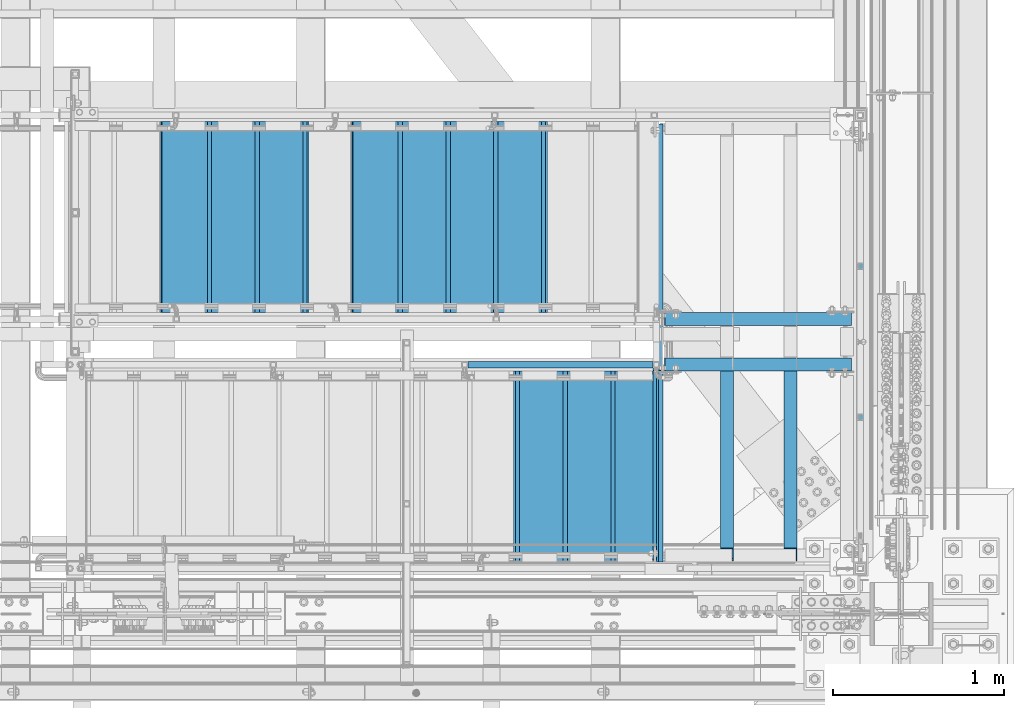
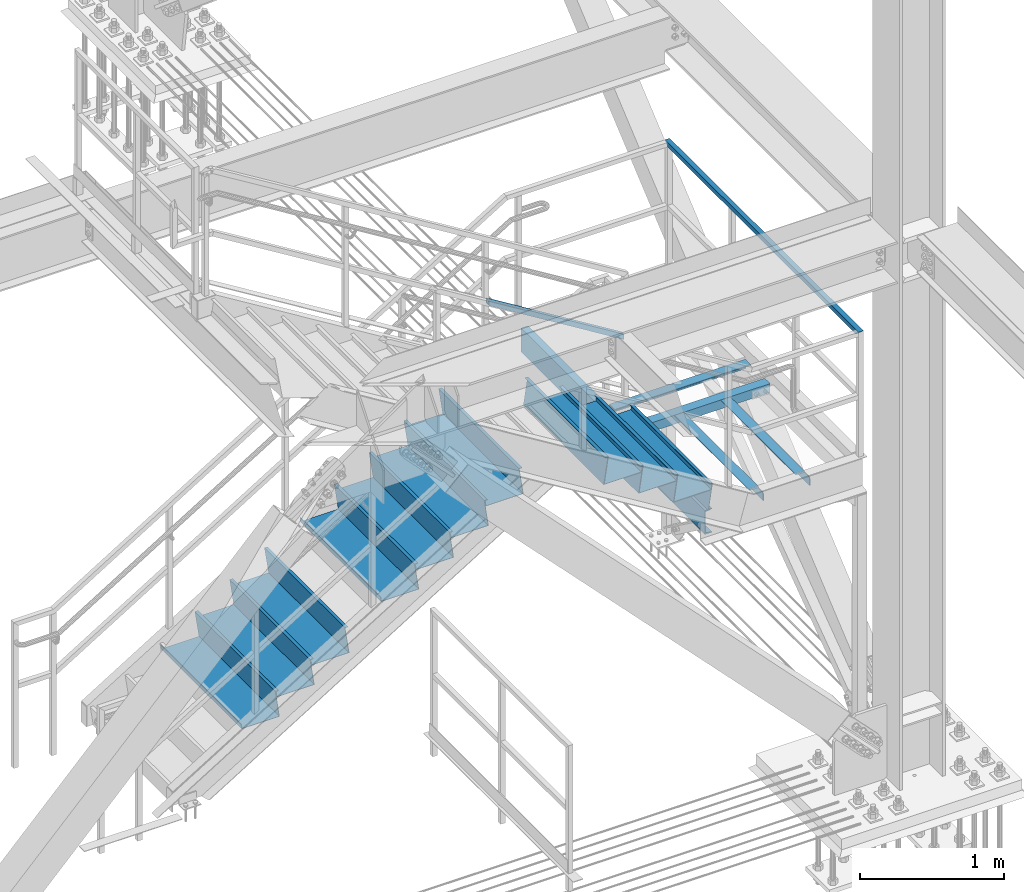
# One storey, part 1948 of 3843: 17 beams, 1 member, 9 elements without a shape of their own.
"""IFC2X3 building model written with IfcOpenShell, lengths in millimetres."""

from ifc_helpers import new_model, si_unit, frame, origin_with_axes, place, context, subcontext, project, spatial, faceted_brep, material, type_object, element, aggregate, save


model = new_model("IFC2X3")

# Units and contexts
model_context = context("Model", 3, precision=1e-05, world=origin_with_axes())
body_context = subcontext(model_context, "Body", "Model", "MODEL_VIEW")
ifc_project = project(units=[si_unit("LENGTHUNIT", "METRE", prefix="MILLI"), si_unit("AREAUNIT", "SQUARE_METRE"), si_unit("VOLUMEUNIT", "CUBIC_METRE"), si_unit("MASSUNIT", "GRAM", prefix="KILO"), si_unit("TIMEUNIT", "SECOND"), si_unit("PLANEANGLEUNIT", "RADIAN"), si_unit("SOLIDANGLEUNIT", "STERADIAN"), si_unit("THERMODYNAMICTEMPERATUREUNIT", "DEGREE_CELSIUS"), si_unit("LUMINOUSINTENSITYUNIT", "LUMEN")], contexts=[model_context])

# Site, building, storey
site_placement = place(None, origin_with_axes())
site = spatial("IfcSite", under=ifc_project, at=site_placement, CompositionType="ELEMENT")
building_placement = place(site_placement, origin_with_axes())
building = spatial("IfcBuilding", under=site, at=building_placement, Name="Undefined", CompositionType="ELEMENT")
storey_placement = place(building_placement, origin_with_axes())
storey = spatial("IfcBuildingStorey", under=building, at=storey_placement, Name="Undefined", CompositionType="ELEMENT", Elevation=0.0)

# Assembly, beam
assembly_1_placement = place(storey_placement, origin_with_axes())
assembly_1 = element("IfcElementAssembly", 1, at=assembly_1_placement, inside=storey, Name="RAIL", AssemblyPlace="NOTDEFINED", PredefinedType="RIGID_FRAME")
ifc_material_1 = material()
beam_type_1 = type_object("IfcBeamType", Name="HSS1-1/2X1-1/2X1/4", PredefinedType="NOTDEFINED")
beam_1_placement = place(assembly_1_placement, frame((85407.499999968, 17938.7499992331, 33781.9999999999), z_axis=(0.0, 0.0, -1.0), x_axis=(0.0, -1.0, 0.0)))
beam_1 = element("IfcBeam", 2, at=beam_1_placement, type_object=beam_type_1, material=ifc_material_1, Name="RAIL", ObjectType="HSS1-1/2X1-1/2X1/4", context=body_context, shape_type="Brep", body=[
    faceted_brep([(6.34999999999854, 12.6999993299978, -12.6999993299978), (6.34999999999854, -12.6999993299978, -12.6999993299978), (2686.04999856405, -12.6999993299978, -12.6999993299978), (2686.04999856405, 12.6999993299978, -12.6999993299978), (31.7500007135677, -12.6999993300014, 12.6999993299978), (2660.64999990405, -12.6999993299978, 12.6999993299978), (31.7500007135677, 12.6999993300014, 12.6999993299978), (2660.64999990405, 12.6999993299978, 12.6999993299978), (0.0, 19.0500000000029, -19.0499999999993), (38.0999984699883, 19.0499992350015, 19.0499992350015), (2654.29999999905, 19.0499992349942, 19.0499992350015), (2692.400000765, 19.0499992350015, -19.0499992350015), (38.0999984699883, -19.0499992350015, 19.0499992350015), (2654.29999999905, -19.0499992349942, 19.0499992350015), (0.0, -19.0499992350015, -19.0499992350015), (2692.400000765, -19.0499992350015, -19.0499992350015)], [[[0, 1, 2, 3]], [[1, 4, 5, 2]], [[4, 6, 7, 5]], [[6, 0, 3, 7]], [[8, 9, 10, 11]], [[9, 12, 13, 10]], [[12, 14, 15, 13]], [[14, 8, 11, 15]], [[13, 15, 11, 10], [5, 7, 3, 2]], [[14, 12, 9, 8], [6, 4, 1, 0]]]),
])
aggregate(assembly_1, [beam_1])

# Assembly, member
assembly_2_placement = place(storey_placement, origin_with_axes())
assembly_2 = element("IfcElementAssembly", 3, at=assembly_2_placement, inside=storey, Name="RAIL", AssemblyPlace="NOTDEFINED", PredefinedType="RIGID_FRAME")
member_type = type_object("IfcMemberType", Name="HSS1-1/2X1-1/2X1/4", PredefinedType="NOTDEFINED")
member_placement = place(assembly_2_placement, frame((84194.6500007382, 16459.2, 33455.7076912289), z_axis=(0.524097425775922, 0.0, 0.851658316635875), x_axis=(-0.851658316635873, 0.0, 0.524097425775925)))
member = element("IfcMember", 4, at=member_placement, type_object=member_type, material=ifc_material_1, Name="RAIL", ObjectType="HSS1-1/2X1-1/2X1/4", context=body_context, shape_type="Brep", body=[
    faceted_brep([(1284.22087624104, -19.0499992350015, 19.049999235649), (1260.77472332956, -19.0499992350015, -19.0499992343102), (1260.77472332956, 19.0499992350015, -19.0499992343102), (1284.22087624104, 19.0499992350015, 19.049999235649), (1280.31318399066, -12.6999993300014, 12.6999993306672), (1280.31318399066, 12.6999993300014, 12.6999993306672), (1264.68241557993, 12.6999993300014, -12.6999993293139), (1264.68241557993, -12.6999993300014, -12.6999993293139), (11.7230764566921, 19.0499992350015, 19.0499992349796), (11.7230764566921, -19.0499992350015, 19.0499992349796), (-11.7230764547858, -19.0499992350015, -19.0499992349942), (-11.7230764547858, 19.0499992350015, -19.0499992349942), (7.81538420631841, 12.6999993300014, 12.6999993299833), (7.81538420631841, -12.6999993300014, 12.6999993299833), (-7.81538420441211, -12.6999993300014, -12.6999993299978), (-7.81538420441211, 12.6999993300014, -12.6999993299978)], [[[0, 1, 2, 3], [4, 5, 6, 7]], [[8, 9, 0, 3]], [[10, 11, 2, 1]], [[9, 10, 1, 0]], [[11, 8, 3, 2]], [[10, 9, 8, 11], [12, 13, 14, 15]], [[14, 13, 4, 7]], [[15, 14, 7, 6]], [[12, 15, 6, 5]], [[13, 12, 5, 4]]]),
])
aggregate(assembly_2, [member])

# Assembly, beams
assembly_3_placement = place(storey_placement, origin_with_axes())
assembly_3 = element("IfcElementAssembly", 5, at=assembly_3_placement, inside=storey, Name="STAIR", AssemblyPlace="NOTDEFINED", PredefinedType="RIGID_FRAME")
ifc_material_2 = material(Name="STEEL/ASTM A1011")
beam_type_2 = type_object("IfcBeamType", PredefinedType="NOTDEFINED")
beam_2_placement = place(assembly_3_placement, frame((83388.1999999869, 15862.300000067, 33401.3663461531), z_axis=(0.0, 1.0, 0.0), x_axis=(1.0, 0.0, 0.0)))
beam_2 = element("IfcBeam", 6, at=beam_2_placement, type_object=beam_type_2, material=ifc_material_2, Name="TREAD", context=body_context, shape_type="Brep", body=[
    faceted_brep([(0.0, -1.58750000000146, -558.799999999999), (0.0, -1.58750000000146, 558.799999999999), (0.0, 1.58750000000146, 558.799999999999), (0.0, 1.58750000000146, -558.799999999999), (21.7215083258779, 1.58750000000146, 558.799999999999), (21.7215083258779, 1.58750000000146, -558.799999999999), (25.3999999999942, -1.58750000000146, -558.799999999999), (25.3999999999942, -1.58750000000146, 558.799999999999), (-11.1830371286633, 224.325961538467, 558.799999999999), (-11.1830371286633, 224.325961538467, -558.799999999999), (-7.50454545454704, 221.150961538464, -558.799999999999), (-7.50454545454704, 221.150961538464, 558.799999999999), (293.616962871325, 224.325961538467, 558.799999999999), (293.616962871325, 224.325961538467, -558.799999999999), (290.876539379024, 221.150961538464, -558.799999999999), (290.876539379024, 221.150961538464, 558.799999999999), (299.585432747743, 183.924011605752, 558.799999999999), (299.585432747743, 183.924011605752, -558.799999999999), (296.444520385252, 183.460013188564, 558.799999999999), (296.444520385252, 183.460013188564, -558.799999999999)], [[[0, 1, 2, 3]], [[3, 2, 4, 5]], [[1, 0, 6, 7]], [[5, 4, 8, 9]], [[7, 6, 10, 11]], [[9, 8, 12, 13]], [[11, 10, 14, 15]], [[13, 12, 16, 17]], [[12, 8, 4, 2, 1, 7, 11, 15, 18, 16]], [[15, 14, 19, 18]], [[14, 10, 6, 0, 3, 5, 9, 13, 17, 19]], [[18, 19, 17, 16]]]),
])
beam_3_placement = place(assembly_3_placement, frame((83667.5999999869, 15862.300000067, 33229.4278846146), z_axis=(0.0, 1.0, 0.0), x_axis=(1.0, 0.0, 0.0)))
beam_3 = element("IfcBeam", 7, at=beam_3_placement, type_object=beam_type_2, material=ifc_material_2, Name="TREAD", context=body_context, shape_type="Brep", body=[
    faceted_brep([(0.0, -1.58750000000146, -558.799999999999), (0.0, -1.58750000000146, 558.799999999999), (0.0, 1.58750000000146, 558.799999999999), (0.0, 1.58750000000146, -558.799999999999), (21.7215083258779, 1.58750000000146, 558.799999999999), (21.7215083258779, 1.58750000000146, -558.799999999999), (25.3999999999942, -1.58750000000146, -558.799999999999), (25.3999999999942, -1.58750000000146, 558.799999999999), (-11.1830371286633, 224.325961538467, 558.799999999999), (-11.1830371286633, 224.325961538467, -558.799999999999), (-7.50454545454704, 221.150961538464, -558.799999999999), (-7.50454545454704, 221.150961538464, 558.799999999999), (293.616962871325, 224.325961538467, 558.799999999999), (293.616962871325, 224.325961538467, -558.799999999999), (290.876539379024, 221.150961538464, -558.799999999999), (290.876539379024, 221.150961538464, 558.799999999999), (299.585432747743, 183.924011605752, 558.799999999999), (299.585432747743, 183.924011605752, -558.799999999999), (296.444520385252, 183.460013188564, 558.799999999999), (296.444520385252, 183.460013188564, -558.799999999999)], [[[0, 1, 2, 3]], [[3, 2, 4, 5]], [[1, 0, 6, 7]], [[5, 4, 8, 9]], [[7, 6, 10, 11]], [[9, 8, 12, 13]], [[11, 10, 14, 15]], [[13, 12, 16, 17]], [[12, 8, 4, 2, 1, 7, 11, 15, 18, 16]], [[15, 14, 19, 18]], [[14, 10, 6, 0, 3, 5, 9, 13, 17, 19]], [[18, 19, 17, 16]]]),
])
beam_4_placement = place(assembly_3_placement, frame((83946.9999999989, 15862.3000000667, 33057.4894230761), z_axis=(0.0, 1.0, 0.0), x_axis=(1.0, 0.0, 0.0)))
beam_4 = element("IfcBeam", 8, at=beam_4_placement, type_object=beam_type_2, material=ifc_material_2, Name="TREAD", context=body_context, shape_type="Brep", body=[
    faceted_brep([(0.0, -1.58750000000146, -558.799999999999), (0.0, -1.58750000000146, 558.799999999999), (0.0, 1.58750000000146, 558.799999999999), (0.0, 1.58750000000146, -558.799999999999), (21.7215083258779, 1.58750000000146, 558.799999999999), (21.7215083258779, 1.58750000000146, -558.799999999999), (25.3999999999942, -1.58750000000146, -558.799999999999), (25.3999999999942, -1.58750000000146, 558.799999999999), (-11.1830371286633, 224.325961538467, 558.799999999999), (-11.1830371286633, 224.325961538467, -558.799999999999), (-7.50454545454704, 221.150961538464, -558.799999999999), (-7.50454545454704, 221.150961538464, 558.799999999999), (293.616962871325, 224.325961538467, 558.799999999999), (293.616962871325, 224.325961538467, -558.799999999999), (290.876539379024, 221.150961538464, -558.799999999999), (290.876539379024, 221.150961538464, 558.799999999999), (299.585432747743, 183.924011605752, 558.799999999999), (299.585432747743, 183.924011605752, -558.799999999999), (296.444520385252, 183.460013188564, 558.799999999999), (296.444520385252, 183.460013188564, -558.799999999999)], [[[0, 1, 2, 3]], [[3, 2, 4, 5]], [[1, 0, 6, 7]], [[5, 4, 8, 9]], [[7, 6, 10, 11]], [[9, 8, 12, 13]], [[11, 10, 14, 15]], [[13, 12, 16, 17]], [[12, 8, 4, 2, 1, 7, 11, 15, 18, 16]], [[15, 14, 19, 18]], [[14, 10, 6, 0, 3, 5, 9, 13, 17, 19]], [[18, 19, 17, 16]]]),
])

assembly_4_placement = place(storey_placement, origin_with_axes())
assembly_4 = element("IfcElementAssembly", 9, at=assembly_4_placement, inside=storey, Name="STAIR", AssemblyPlace="NOTDEFINED", PredefinedType="RIGID_FRAME")
beam_5_placement = place(assembly_4_placement, frame((83566.0000000127, 17322.7999999318, 32369.7355769222), z_axis=(0.0, -1.0, 0.0), x_axis=(-1.0, 0.0, 0.0)))
beam_5 = element("IfcBeam", 10, at=beam_5_placement, type_object=beam_type_2, material=ifc_material_2, Name="TREAD", context=body_context, shape_type="Brep", body=[
    faceted_brep([(0.0, -1.58750000000146, -558.799999999999), (0.0, -1.58750000000146, 558.799999999999), (0.0, 1.58750000000146, 558.799999999999), (0.0, 1.58750000000146, -558.799999999999), (21.7215083258779, 1.58750000000146, 558.799999999999), (21.7215083258779, 1.58750000000146, -558.799999999999), (25.3999999999942, -1.58750000000146, -558.799999999999), (25.3999999999942, -1.58750000000146, 558.799999999999), (-11.1830371286633, 224.325961538467, 558.799999999999), (-11.1830371286633, 224.325961538467, -558.799999999999), (-7.50454545454704, 221.150961538464, -558.799999999999), (-7.50454545454704, 221.150961538464, 558.799999999999), (293.616962871325, 224.325961538467, 558.799999999999), (293.616962871325, 224.325961538467, -558.799999999999), (290.876539379024, 221.150961538464, -558.799999999999), (290.876539379024, 221.150961538464, 558.799999999999), (299.585432747743, 183.924011605752, 558.799999999999), (299.585432747743, 183.924011605752, -558.799999999999), (296.444520385252, 183.460013188564, 558.799999999999), (296.444520385252, 183.460013188564, -558.799999999999)], [[[0, 1, 2, 3]], [[3, 2, 4, 5]], [[1, 0, 6, 7]], [[5, 4, 8, 9]], [[7, 6, 10, 11]], [[9, 8, 12, 13]], [[11, 10, 14, 15]], [[13, 12, 16, 17]], [[12, 8, 4, 2, 1, 7, 11, 15, 18, 16]], [[15, 14, 19, 18]], [[14, 10, 6, 0, 3, 5, 9, 13, 17, 19]], [[18, 19, 17, 16]]]),
])
beam_6_placement = place(assembly_4_placement, frame((83286.6000000127, 17322.7999999318, 32197.7971153837), z_axis=(0.0, -1.0, 0.0), x_axis=(-1.0, 0.0, 0.0)))
beam_6 = element("IfcBeam", 11, at=beam_6_placement, type_object=beam_type_2, material=ifc_material_2, Name="TREAD", context=body_context, shape_type="Brep", body=[
    faceted_brep([(0.0, -1.58750000000146, -558.799999999999), (0.0, -1.58750000000146, 558.799999999999), (0.0, 1.58750000000146, 558.799999999999), (0.0, 1.58750000000146, -558.799999999999), (21.7215083258779, 1.58750000000146, 558.799999999999), (21.7215083258779, 1.58750000000146, -558.799999999999), (25.3999999999942, -1.58750000000146, -558.799999999999), (25.3999999999942, -1.58750000000146, 558.799999999999), (-11.1830371286633, 224.325961538467, 558.799999999999), (-11.1830371286633, 224.325961538467, -558.799999999999), (-7.50454545454704, 221.150961538464, -558.799999999999), (-7.50454545454704, 221.150961538464, 558.799999999999), (293.616962871325, 224.325961538467, 558.799999999999), (293.616962871325, 224.325961538467, -558.799999999999), (290.876539379024, 221.150961538464, -558.799999999999), (290.876539379024, 221.150961538464, 558.799999999999), (299.585432747743, 183.924011605752, 558.799999999999), (299.585432747743, 183.924011605752, -558.799999999999), (296.444520385252, 183.460013188564, 558.799999999999), (296.444520385252, 183.460013188564, -558.799999999999)], [[[0, 1, 2, 3]], [[3, 2, 4, 5]], [[1, 0, 6, 7]], [[5, 4, 8, 9]], [[7, 6, 10, 11]], [[9, 8, 12, 13]], [[11, 10, 14, 15]], [[13, 12, 16, 17]], [[12, 8, 4, 2, 1, 7, 11, 15, 18, 16]], [[15, 14, 19, 18]], [[14, 10, 6, 0, 3, 5, 9, 13, 17, 19]], [[18, 19, 17, 16]]]),
])
beam_7_placement = place(assembly_4_placement, frame((83007.2000000127, 17322.7999999318, 32025.8586538453), z_axis=(0.0, -1.0, 0.0), x_axis=(-1.0, 0.0, 0.0)))
beam_7 = element("IfcBeam", 12, at=beam_7_placement, type_object=beam_type_2, material=ifc_material_2, Name="TREAD", context=body_context, shape_type="Brep", body=[
    faceted_brep([(0.0, -1.58750000000146, -558.799999999999), (0.0, -1.58750000000146, 558.799999999999), (0.0, 1.58750000000146, 558.799999999999), (0.0, 1.58750000000146, -558.799999999999), (21.7215083258779, 1.58750000000146, 558.799999999999), (21.7215083258779, 1.58750000000146, -558.799999999999), (25.3999999999942, -1.58750000000146, -558.799999999999), (25.3999999999942, -1.58750000000146, 558.799999999999), (-11.1830371286633, 224.325961538467, 558.799999999999), (-11.1830371286633, 224.325961538467, -558.799999999999), (-7.50454545454704, 221.150961538464, -558.799999999999), (-7.50454545454704, 221.150961538464, 558.799999999999), (293.616962871325, 224.325961538467, 558.799999999999), (293.616962871325, 224.325961538467, -558.799999999999), (290.876539379024, 221.150961538464, -558.799999999999), (290.876539379024, 221.150961538464, 558.799999999999), (299.585432747743, 183.924011605752, 558.799999999999), (299.585432747743, 183.924011605752, -558.799999999999), (296.444520385252, 183.460013188564, 558.799999999999), (296.444520385252, 183.460013188564, -558.799999999999)], [[[0, 1, 2, 3]], [[3, 2, 4, 5]], [[1, 0, 6, 7]], [[5, 4, 8, 9]], [[7, 6, 10, 11]], [[9, 8, 12, 13]], [[11, 10, 14, 15]], [[13, 12, 16, 17]], [[12, 8, 4, 2, 1, 7, 11, 15, 18, 16]], [[15, 14, 19, 18]], [[14, 10, 6, 0, 3, 5, 9, 13, 17, 19]], [[18, 19, 17, 16]]]),
])
beam_8_placement = place(assembly_4_placement, frame((82727.8000000127, 17322.7999999318, 31853.9201923068), z_axis=(0.0, -1.0, 0.0), x_axis=(-1.0, 0.0, 0.0)))
beam_8 = element("IfcBeam", 13, at=beam_8_placement, type_object=beam_type_2, material=ifc_material_2, Name="TREAD", context=body_context, shape_type="Brep", body=[
    faceted_brep([(0.0, -1.58750000000146, -558.799999999999), (0.0, -1.58750000000146, 558.799999999999), (0.0, 1.58750000000146, 558.799999999999), (0.0, 1.58750000000146, -558.799999999999), (21.7215083258779, 1.58750000000146, 558.799999999999), (21.7215083258779, 1.58750000000146, -558.799999999999), (25.3999999999942, -1.58750000000146, -558.799999999999), (25.3999999999942, -1.58750000000146, 558.799999999999), (-11.1830371286633, 224.325961538467, 558.799999999999), (-11.1830371286633, 224.325961538467, -558.799999999999), (-7.50454545454704, 221.150961538464, -558.799999999999), (-7.50454545454704, 221.150961538464, 558.799999999999), (293.616962871325, 224.325961538467, 558.799999999999), (293.616962871325, 224.325961538467, -558.799999999999), (290.876539379024, 221.150961538464, -558.799999999999), (290.876539379024, 221.150961538464, 558.799999999999), (299.585432747743, 183.924011605752, 558.799999999999), (299.585432747743, 183.924011605752, -558.799999999999), (296.444520385252, 183.460013188564, 558.799999999999), (296.444520385252, 183.460013188564, -558.799999999999)], [[[0, 1, 2, 3]], [[3, 2, 4, 5]], [[1, 0, 6, 7]], [[5, 4, 8, 9]], [[7, 6, 10, 11]], [[9, 8, 12, 13]], [[11, 10, 14, 15]], [[13, 12, 16, 17]], [[12, 8, 4, 2, 1, 7, 11, 15, 18, 16]], [[15, 14, 19, 18]], [[14, 10, 6, 0, 3, 5, 9, 13, 17, 19]], [[18, 19, 17, 16]]]),
])
beam_9_placement = place(assembly_4_placement, frame((82169.0000000127, 17322.7999999318, 31510.0432692299), z_axis=(0.0, -1.0, 0.0), x_axis=(-1.0, 0.0, 0.0)))
beam_9 = element("IfcBeam", 14, at=beam_9_placement, type_object=beam_type_2, material=ifc_material_2, Name="TREAD", context=body_context, shape_type="Brep", body=[
    faceted_brep([(0.0, -1.58750000000146, -558.799999999999), (0.0, -1.58750000000146, 558.799999999999), (0.0, 1.58750000000146, 558.799999999999), (0.0, 1.58750000000146, -558.799999999999), (21.7215083258779, 1.58750000000146, 558.799999999999), (21.7215083258779, 1.58750000000146, -558.799999999999), (25.3999999999942, -1.58750000000146, -558.799999999999), (25.3999999999942, -1.58750000000146, 558.799999999999), (-11.1830371286633, 224.325961538467, 558.799999999999), (-11.1830371286633, 224.325961538467, -558.799999999999), (-7.50454545454704, 221.150961538464, -558.799999999999), (-7.50454545454704, 221.150961538464, 558.799999999999), (293.616962871325, 224.325961538467, 558.799999999999), (293.616962871325, 224.325961538467, -558.799999999999), (290.876539379024, 221.150961538464, -558.799999999999), (290.876539379024, 221.150961538464, 558.799999999999), (299.585432747743, 183.924011605752, 558.799999999999), (299.585432747743, 183.924011605752, -558.799999999999), (296.444520385252, 183.460013188564, 558.799999999999), (296.444520385252, 183.460013188564, -558.799999999999)], [[[0, 1, 2, 3]], [[3, 2, 4, 5]], [[1, 0, 6, 7]], [[5, 4, 8, 9]], [[7, 6, 10, 11]], [[9, 8, 12, 13]], [[11, 10, 14, 15]], [[13, 12, 16, 17]], [[12, 8, 4, 2, 1, 7, 11, 15, 18, 16]], [[15, 14, 19, 18]], [[14, 10, 6, 0, 3, 5, 9, 13, 17, 19]], [[18, 19, 17, 16]]]),
])
beam_10_placement = place(assembly_4_placement, frame((81889.6000000127, 17322.7999999318, 31338.1048076914), z_axis=(0.0, -1.0, 0.0), x_axis=(-1.0, 0.0, 0.0)))
beam_10 = element("IfcBeam", 15, at=beam_10_placement, type_object=beam_type_2, material=ifc_material_2, Name="TREAD", context=body_context, shape_type="Brep", body=[
    faceted_brep([(0.0, -1.58750000000146, -558.799999999999), (0.0, -1.58750000000146, 558.799999999999), (0.0, 1.58750000000146, 558.799999999999), (0.0, 1.58750000000146, -558.799999999999), (21.7215083258779, 1.58750000000146, 558.799999999999), (21.7215083258779, 1.58750000000146, -558.799999999999), (25.3999999999942, -1.58750000000146, -558.799999999999), (25.3999999999942, -1.58750000000146, 558.799999999999), (-11.1830371286633, 224.325961538467, 558.799999999999), (-11.1830371286633, 224.325961538467, -558.799999999999), (-7.50454545454704, 221.150961538464, -558.799999999999), (-7.50454545454704, 221.150961538464, 558.799999999999), (293.616962871325, 224.325961538467, 558.799999999999), (293.616962871325, 224.325961538467, -558.799999999999), (290.876539379024, 221.150961538464, -558.799999999999), (290.876539379024, 221.150961538464, 558.799999999999), (299.585432747743, 183.924011605752, 558.799999999999), (299.585432747743, 183.924011605752, -558.799999999999), (296.444520385252, 183.460013188564, 558.799999999999), (296.444520385252, 183.460013188564, -558.799999999999)], [[[0, 1, 2, 3]], [[3, 2, 4, 5]], [[1, 0, 6, 7]], [[5, 4, 8, 9]], [[7, 6, 10, 11]], [[9, 8, 12, 13]], [[11, 10, 14, 15]], [[13, 12, 16, 17]], [[12, 8, 4, 2, 1, 7, 11, 15, 18, 16]], [[15, 14, 19, 18]], [[14, 10, 6, 0, 3, 5, 9, 13, 17, 19]], [[18, 19, 17, 16]]]),
])
beam_11_placement = place(assembly_4_placement, frame((81610.2000000127, 17322.7999999318, 31166.166346153), z_axis=(0.0, -1.0, 0.0), x_axis=(-1.0, 0.0, 0.0)))
beam_11 = element("IfcBeam", 16, at=beam_11_placement, type_object=beam_type_2, material=ifc_material_2, Name="TREAD", context=body_context, shape_type="Brep", body=[
    faceted_brep([(0.0, -1.58750000000146, -558.799999999999), (0.0, -1.58750000000146, 558.799999999999), (0.0, 1.58750000000146, 558.799999999999), (0.0, 1.58750000000146, -558.799999999999), (21.7215083258779, 1.58750000000146, 558.799999999999), (21.7215083258779, 1.58750000000146, -558.799999999999), (25.3999999999942, -1.58750000000146, -558.799999999999), (25.3999999999942, -1.58750000000146, 558.799999999999), (-11.1830371286633, 224.325961538467, 558.799999999999), (-11.1830371286633, 224.325961538467, -558.799999999999), (-7.50454545454704, 221.150961538464, -558.799999999999), (-7.50454545454704, 221.150961538464, 558.799999999999), (293.616962871325, 224.325961538467, 558.799999999999), (293.616962871325, 224.325961538467, -558.799999999999), (290.876539379024, 221.150961538464, -558.799999999999), (290.876539379024, 221.150961538464, 558.799999999999), (299.585432747743, 183.924011605752, 558.799999999999), (299.585432747743, 183.924011605752, -558.799999999999), (296.444520385252, 183.460013188564, 558.799999999999), (296.444520385252, 183.460013188564, -558.799999999999)], [[[0, 1, 2, 3]], [[3, 2, 4, 5]], [[1, 0, 6, 7]], [[5, 4, 8, 9]], [[7, 6, 10, 11]], [[9, 8, 12, 13]], [[11, 10, 14, 15]], [[13, 12, 16, 17]], [[12, 8, 4, 2, 1, 7, 11, 15, 18, 16]], [[15, 14, 19, 18]], [[14, 10, 6, 0, 3, 5, 9, 13, 17, 19]], [[18, 19, 17, 16]]]),
])
aggregate(assembly_4, [beam_5, beam_6, beam_7, beam_8, beam_9, beam_10, beam_11])

# Assembly, beam
assembly_5_placement = place(storey_placement, origin_with_axes())
assembly_5 = element("IfcElementAssembly", 17, at=assembly_5_placement, inside=storey, Name="ANGLE", AssemblyPlace="NOTDEFINED", PredefinedType="RIGID_FRAME")
ifc_material_3 = material(Name="STEEL/A36")
beam_type_3 = type_object("IfcBeamType", Name="L3X3X1/4", PredefinedType="NOTDEFINED")
beam_12_placement = place(assembly_5_placement, frame((85356.700000278, 16459.2000000683, 32626.2999999741), z_axis=(0.0, 1.0, 0.0), x_axis=(-1.0, 0.0, 0.0)))
beam_12 = element("IfcBeam", 18, at=beam_12_placement, type_object=beam_type_3, material=ifc_material_3, Name="ANGLE", ObjectType="L3X3X1/4", context=body_context, shape_type="Brep", body=[
    faceted_brep([(1093.16673012289, 33.2399238430298, 38.0999999999985), (1093.16673012289, 33.2399238430298, -38.0999999999985), (1092.20000022635, 38.0999999990308, -38.0999999999985), (1092.20000022635, 38.0999999990308, 38.0999999999985), (1095.91974394856, 29.1197474128239, -31.75), (1095.91974394856, 29.1197474128239, -38.0999999999985), (1094.16226538971, 31.7499999990287, 38.0999999999985), (1094.16226538971, 31.7499999990287, -31.75), (1100.03992031692, 26.3667334945749, -31.75), (1100.03992031692, 26.3667334945749, -38.0999999999985), (1104.89999974388, 25.4000034888413, -31.75), (1104.89999974388, 25.4000034888413, -38.0999999999985), (1143.00000042596, 25.4000026133508, -31.75), (1143.00000042596, 25.4000026133508, -38.0999999999985), (1155.70000026358, 12.7000025178604, -31.75), (1155.70000025244, 12.7000025178604, -38.0999999999985), (0.0, -38.0999999999985, -38.0999999999985), (0.0, -38.0999999999985, -31.75), (0.0, 31.75, -31.75), (0.0, 31.75, 38.0999999999985), (0.0, 38.0999999999985, 38.0999999999985), (0.0, 38.0999999999985, -38.0999999999985), (1155.70000035442, -38.1000000010245, -38.0999999999985), (1155.70000035442, -38.1000000010245, -31.75)], [[[0, 1, 2, 3]], [[4, 5, 1, 0, 6, 7]], [[8, 9, 5, 4]], [[10, 11, 9, 8]], [[12, 13, 11, 10]], [[14, 15, 13, 12]], [[16, 17, 18, 19, 20, 21]], [[17, 16, 22, 23]], [[10, 8, 4, 7, 18, 17, 23, 14, 12]], [[19, 18, 7, 6]], [[3, 20, 19, 6, 0]], [[21, 20, 3, 2]], [[22, 16, 21, 2, 1, 5, 9, 11, 13, 15]], [[23, 22, 15, 14]]]),
])
aggregate(assembly_5, [beam_12])

assembly_6_placement = place(storey_placement, origin_with_axes())
assembly_6 = element("IfcElementAssembly", 19, at=assembly_6_placement, inside=storey, Name="ANGLE", AssemblyPlace="NOTDEFINED", PredefinedType="RIGID_FRAME")
beam_13_placement = place(assembly_6_placement, frame((84998.9833333383, 16421.1000000689, 32626.2999999982), z_axis=(-1.0, 0.0, 0.0), x_axis=(0.0, -1.0, 0.0)))
beam_13 = element("IfcBeam", 20, at=beam_13_placement, type_object=beam_type_3, material=ifc_material_3, Name="ANGLE", ObjectType="L3X3X1/4", context=body_context, shape_type="Brep", body=[
    faceted_brep([(1041.40000012286, 31.75, 38.0999999999985), (1041.40000012286, 31.75, -31.75), (1041.40000012286, 31.7499999942156, -38.0999999999985), (1035.05000012226, 38.0999999999985, -38.0999999999985), (1035.05000012226, 38.0999999999985, 38.0999999999985), (1098.55000012286, 31.75, -31.75), (1098.55000012286, 31.7499999942156, -38.0999999999985), (1111.25000012285, 19.0499999942185, -31.75), (1111.25000012285, 19.0499999942185, -38.0999999999985), (1111.25000012344, -38.1000000057757, -31.75), (1111.25000012344, -38.0999999999985, -38.0999999999985), (0.0, -38.0999999999985, -38.0999999999985), (0.0, -38.0999999999985, -31.75), (0.0, 31.75, -31.75), (0.0, 31.75, 38.0999999999985), (0.0, 38.0999999999985, 38.0999999999985), (0.0, 38.0999999999985, -38.0999999999985)], [[[0, 1, 2, 3, 4]], [[5, 6, 2, 1]], [[7, 8, 6, 5]], [[9, 10, 8, 7]], [[11, 12, 13, 14, 15, 16]], [[5, 1, 13, 12, 9, 7]], [[14, 13, 1, 0]], [[15, 14, 0, 4]], [[16, 15, 4, 3]], [[11, 16, 3, 2, 6, 8, 10]], [[12, 11, 10, 9]]]),
])
aggregate(assembly_6, [beam_13])

assembly_7_placement = place(storey_placement, origin_with_axes())
assembly_7 = element("IfcElementAssembly", 21, at=assembly_7_placement, inside=storey, Name="ANGLE", AssemblyPlace="NOTDEFINED", PredefinedType="RIGID_FRAME")
beam_14_placement = place(assembly_7_placement, frame((84626.45, 16421.1000000689, 32626.2999999982), z_axis=(-1.0, 0.0, 0.0), x_axis=(0.0, -1.0, 0.0)))
beam_14 = element("IfcBeam", 22, at=beam_14_placement, type_object=beam_type_3, material=ifc_material_3, Name="ANGLE", ObjectType="L3X3X1/4", context=body_context, shape_type="Brep", body=[
    faceted_brep([(1041.40000012286, 31.75, 38.0999999999985), (1041.40000012286, 31.75, -31.75), (1041.40000012286, 31.7499999942156, -38.0999999999985), (1035.05000012226, 38.0999999999985, -38.0999999999985), (1035.05000012226, 38.0999999999985, 38.0999999999985), (1098.55000012286, 31.75, -31.75), (1098.55000012286, 31.7499999942156, -38.0999999999985), (1111.25000012285, 19.0499999942185, -31.75), (1111.25000012285, 19.0499999942185, -38.0999999999985), (1111.25000012344, -38.1000000057757, -31.75), (1111.25000012344, -38.0999999999985, -38.0999999999985), (0.0, -38.0999999999985, -38.0999999999985), (0.0, -38.0999999999985, -31.75), (0.0, 31.75, -31.75), (0.0, 31.75, 38.0999999999985), (0.0, 38.0999999999985, 38.0999999999985), (0.0, 38.0999999999985, -38.0999999999985)], [[[0, 1, 2, 3, 4]], [[5, 6, 2, 1]], [[7, 8, 6, 5]], [[9, 10, 8, 7]], [[11, 12, 13, 14, 15, 16]], [[5, 1, 13, 12, 9, 7]], [[14, 13, 1, 0]], [[15, 14, 0, 4]], [[16, 15, 4, 3]], [[11, 16, 3, 2, 6, 8, 10]], [[12, 11, 10, 9]]]),
])
aggregate(assembly_7, [beam_14])

assembly_8_placement = place(storey_placement, origin_with_axes())
assembly_8 = element("IfcElementAssembly", 23, at=assembly_8_placement, inside=storey, Name="ANGLE", AssemblyPlace="NOTDEFINED", PredefinedType="RIGID_FRAME")
beam_15_placement = place(assembly_8_placement, frame((84194.6500000723, 16725.9, 32626.299997768), z_axis=(0.0, -1.0, 0.0), x_axis=(1.0, 0.0, 0.0)))
beam_15 = element("IfcBeam", 24, at=beam_15_placement, type_object=beam_type_3, material=ifc_material_3, Name="ANGLE", ObjectType="L3X3X1/4", context=body_context, shape_type="Brep", body=[
    faceted_brep([(19.0499997796433, 25.4000025038549, -31.75), (19.0499997796433, 25.4000025038549, -38.0999999999985), (6.34999995316321, 12.7000024083645, -38.0999999999985), (6.34999995316321, 12.7000024083645, -31.75), (57.1500004617264, 25.4000033793454, -31.75), (57.1500004617264, 25.4000033793454, -38.0999999999985), (62.0100798886851, 26.366733385079, -31.75), (62.0100798886851, 26.366733385079, -38.0999999999985), (66.130256257049, 29.119747303328, -31.75), (66.130256257049, 29.119747303328, -38.0999999999985), (68.8832700827188, 33.2399237335339, 38.0999999999985), (68.8832700827188, 33.2399237335339, -38.0999999999985), (67.8877348897513, 31.7500000000582, -31.75), (67.8877348897513, 31.7500000000582, 38.0999999999985), (69.8499999792548, 38.1000036711775, 38.0999999999985), (69.8499999792548, 38.100000000064, -38.0999999999985), (6.34999999941647, -38.0999999999985, -31.75), (6.34999999941647, -38.0999999999985, -38.0999999999985), (1162.05000020537, -38.099999998969, -38.0999999999985), (1162.05000020537, -38.099999998969, -31.75), (1162.05000020581, 31.7500000010295, 38.0999999999985), (1162.05000020581, 31.7500000010295, -31.75), (1162.05000020585, 38.1000000010317, -38.0999999999985), (1162.05000020585, 38.1000000010317, 38.0999999999985)], [[[0, 1, 2, 3]], [[4, 5, 1, 0]], [[6, 7, 5, 4]], [[8, 9, 7, 6]], [[10, 11, 9, 8, 12, 13]], [[14, 15, 11, 10]], [[16, 17, 18, 19]], [[20, 21, 19, 18, 22, 23]], [[13, 20, 23, 14, 10]], [[21, 20, 13, 12]], [[6, 4, 0, 3, 16, 19, 21, 12, 8]], [[17, 16, 3, 2]], [[22, 18, 17, 2, 1, 5, 7, 9, 11, 15]], [[23, 22, 15, 14]]]),
])
aggregate(assembly_8, [beam_15])

assembly_9_placement = place(storey_placement, origin_with_axes())
assembly_9 = element("IfcElementAssembly", 25, at=assembly_9_placement, inside=storey, Name="BEAM", AssemblyPlace="NOTDEFINED", PredefinedType="RIGID_FRAME")
beam_type_4 = type_object("IfcBeamType", Name="C8X11.5", PredefinedType="NOTDEFINED")
beam_16_placement = place(assembly_9_placement, frame((84223.225, 15227.300000054, 32562.7999999982), z_axis=(0.0, 0.0, 1.0), x_axis=(0.0, 1.0, 0.0)))
beam_16 = element("IfcBeam", 26, at=beam_16_placement, type_object=beam_type_4, material=ifc_material_3, Name="BEAM", ObjectType="C8X11.5", context=body_context, shape_type="Brep", body=[
    faceted_brep([(88.8999999106982, -28.5749999999971, -96.8355950000005), (88.8999999106982, -28.5749999999971, -101.599999999999), (2641.60000000037, -28.5749999999971, -101.599999999999), (2641.60000000037, -28.5749999999971, -96.8355950000005), (88.8999999106982, 22.2250000000058, -88.3723150000005), (2641.60000000037, 22.2250000000058, -88.3723150000005), (88.8999999106982, 22.2250000000058, 88.3723150000005), (2641.60000000037, 22.2250000000058, -78.2000000000007), (2641.60000000037, 22.2250000000058, 76.2000000000007), (2641.60000000037, 22.2250000000058, 88.3723150000005), (88.8999999106982, -28.5749999999971, 96.8355950000005), (2641.60000000037, -28.5749999999971, 96.8355950000005), (88.8999999106982, -28.5749999999971, 101.599999999999), (2641.60000000037, -28.5749999999971, 101.599999999999), (88.8999999106982, 28.5749999999971, 101.599999999999), (2641.60000000037, 28.5749999999971, 101.599999999999), (88.8999999106982, 28.5749999999971, -101.599999999999), (2641.60000000037, 28.5749999999971, -101.599999999999)], [[[0, 1, 2, 3]], [[4, 0, 3, 5]], [[6, 4, 5, 7, 8, 9]], [[10, 6, 9, 11]], [[12, 10, 11, 13]], [[14, 12, 13, 15]], [[1, 0, 4, 6, 10, 12, 14, 16]], [[1, 16, 17, 2]], [[13, 11, 9, 8, 7, 5, 3, 2, 17, 15]], [[16, 14, 15, 17]]]),
])
aggregate(assembly_9, [beam_16])

# Beam
beam_type_5 = type_object("IfcBeamType", PredefinedType="NOTDEFINED")
beam_17_placement = place(assembly_3_placement, frame((84226.3999999947, 15862.299999861, 32885.5509615469), z_axis=(0.0, -1.0, 0.0), x_axis=(1.0, 0.0, 0.0)))
beam_17 = element("IfcBeam", 27, at=beam_17_placement, type_object=beam_type_5, material=ifc_material_2, Name="TREAD", context=body_context, shape_type="Brep", body=[
    faceted_brep([(0.0, -1.58750000000146, -558.799999999999), (0.0, -1.58750000000146, 558.799999999999), (0.0, 1.58750000000146, 558.799999999999), (0.0, 1.58750000000146, -558.799999999999), (25.3999999775115, 1.58750000000146, 558.799999999999), (25.3999999775115, 1.58750000000146, -558.799999999999), (21.7137102561828, -1.58750000000146, -558.799999999999), (21.7137102561828, -1.58750000000146, 558.799999999999), (-7.50559126239386, -217.97596154701, 558.799999999999), (-7.50559126239386, -217.97596154701, -558.799999999999), (-11.1918808373885, -221.150960570576, -558.799999999999), (-11.1918808373885, -221.150960570576, 558.799999999999), (3.17500002775341, -217.975964376117, 558.799999999999), (3.17500002775341, -217.975964376117, -558.799999999999), (3.17499918674002, -221.15096437612, 558.799999999999), (3.17499918674002, -221.15096437612, -558.799999999999)], [[[0, 1, 2, 3]], [[3, 2, 4, 5]], [[1, 0, 6, 7]], [[5, 4, 8, 9]], [[7, 6, 10, 11]], [[9, 8, 12, 13]], [[8, 4, 2, 1, 7, 11, 14, 12]], [[11, 10, 15, 14]], [[10, 6, 0, 3, 5, 9, 13, 15]], [[14, 15, 13, 12]]]),
])

aggregate(assembly_3, [beam_17, beam_2, beam_3, beam_4])

save(model, "model.ifc")
